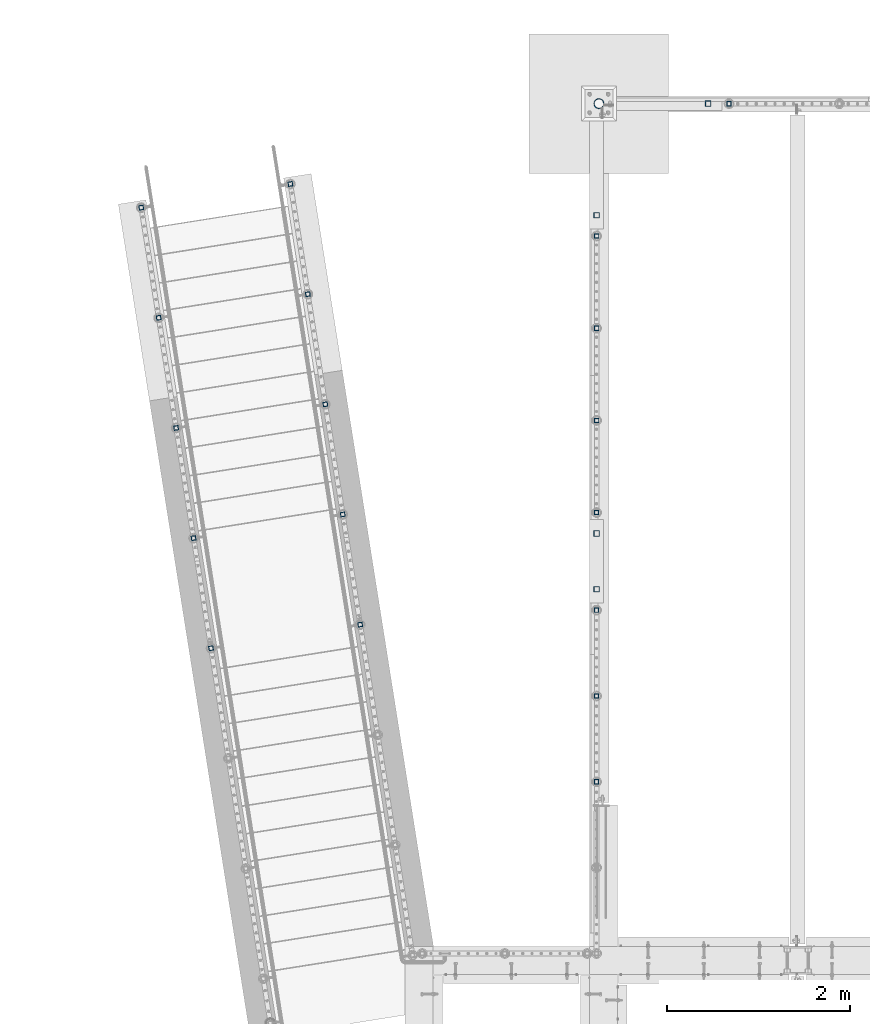
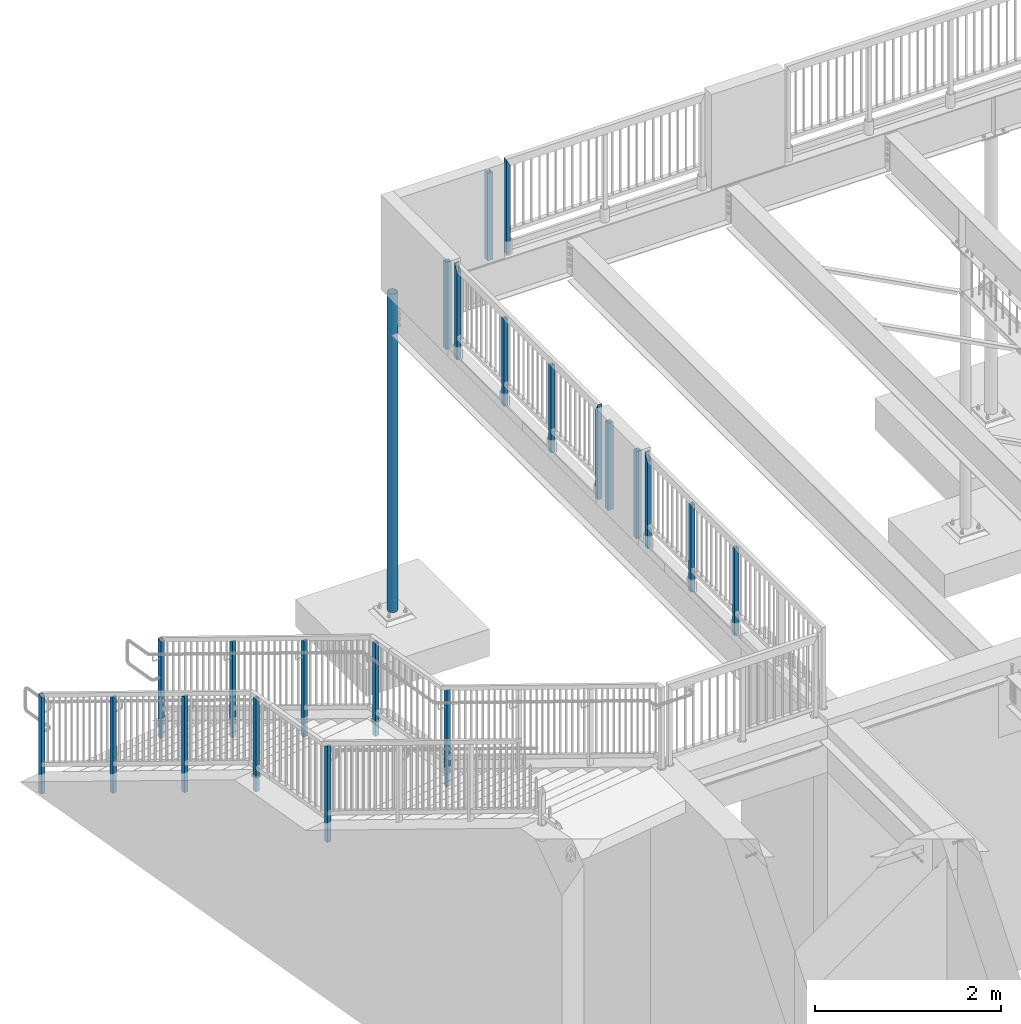
# One storey, part 126 of 975: 23 columns.
"""IFC2X3 building model written with IfcOpenShell, lengths in millimetres."""

from ifc_helpers import new_model, si_unit, frame, origin_with_axes, place, context, subcontext, project, spatial, faceted_brep, material, type_object, element, save


model = new_model("IFC2X3")

# Units and contexts
model_context = context("Model", 3, precision=1e-05, world=origin_with_axes())
body_context = subcontext(model_context, "Body", "Model", "MODEL_VIEW")
ifc_project = project(units=[si_unit("LENGTHUNIT", "METRE", prefix="MILLI"), si_unit("AREAUNIT", "SQUARE_METRE"), si_unit("VOLUMEUNIT", "CUBIC_METRE"), si_unit("MASSUNIT", "GRAM", prefix="KILO"), si_unit("TIMEUNIT", "SECOND"), si_unit("PLANEANGLEUNIT", "RADIAN"), si_unit("SOLIDANGLEUNIT", "STERADIAN"), si_unit("THERMODYNAMICTEMPERATUREUNIT", "DEGREE_CELSIUS"), si_unit("LUMINOUSINTENSITYUNIT", "LUMEN")], contexts=[model_context])

# Site, building, storey
site_placement = place(None, origin_with_axes())
site = spatial("IfcSite", under=ifc_project, at=site_placement, CompositionType="ELEMENT")
building_placement = place(site_placement, origin_with_axes())
building = spatial("IfcBuilding", under=site, at=building_placement, Name="Undefined", CompositionType="ELEMENT")
storey_placement = place(building_placement, origin_with_axes())
storey = spatial("IfcBuildingStorey", under=building, at=storey_placement, Name="Undefined", CompositionType="ELEMENT", Elevation=0.0)

# Columns
ifc_material_1 = material()
column_type_1 = type_object("IfcColumnType", Name="HSS2X2X.188_TUBES", PredefinedType="NOTDEFINED")
column_1_placement = place(storey_placement, frame((3540.12496949157, 29961.8003208815, 3937.00001178547), z_axis=(1.0, 0.0, 0.0), x_axis=(0.0, 0.0, 1.0)))
element("IfcColumn", 1, at=column_1_placement, inside=storey, type_object=column_type_1, material=ifc_material_1, Name="HANDRAIL", ObjectType="HSS2X2X.188_TUBES", context=body_context, shape_type="Brep", body=[
    faceted_brep([(0.0, 20.6374999999753, -20.6375000000298), (0.0, -20.6375000000153, -20.6375000000153), (1235.074979717, -20.6374999999462, -20.6374999999462), (1235.07091767483, 20.6374999999871, -20.6375000000007), (0.0, -20.6374999999825, 20.6375000000335), (1152.52905859553, -20.6375000000121, 20.6375000000007), (0.0, 20.6375000000116, 20.6375000000189), (1152.52497980387, 20.6374999999534, 20.6374999999534), (0.0, 25.3999999999724, -25.4000000000342), (0.0, 25.400000000016, 25.4000000000196), (1143.0, 25.4000000000051, 25.4000000000378), (1244.59497833782, 25.3999999999869, -25.4000000000015), (0.0, -25.399999999976, 25.4000000000378), (1143.00499793254, -25.4000000000121, 25.4000000000015), (0.0, -25.400000000016, -25.4000000000196), (1244.59997970698, -25.399999999936, -25.399999999936)], [[[0, 1, 2, 3]], [[1, 4, 5, 2]], [[4, 6, 7, 5]], [[6, 0, 3, 7]], [[8, 9, 10, 11]], [[9, 12, 13, 10]], [[12, 14, 15, 13]], [[14, 8, 11, 15]], [[13, 15, 11, 10], [5, 7, 3, 2]], [[14, 12, 9, 8], [6, 4, 1, 0]]]),
])
column_2_placement = place(storey_placement, frame((2091.88364504242, 22548.8490121375, 3937.00000847692), z_axis=(0.0, 1.0, 0.0), x_axis=(0.0, 0.0, 1.0)))
element("IfcColumn", 2, at=column_2_placement, inside=storey, type_object=column_type_1, material=ifc_material_1, Name="HANDRAIL", ObjectType="HSS2X2X.188_TUBES", context=body_context, shape_type="Brep", body=[
    faceted_brep([(0.0, 20.6374999999753, -20.6375000000298), (0.0, -20.6375000000153, -20.6375000000153), (1142.99998821453, -20.6374999999462, -20.6374999999534), (1142.99998821453, 20.6374999999462, -20.6374999999516), (0.0, -20.6374999999825, 20.6375000000335), (1142.9999881907, -20.6375000000262, 20.6375000000335), (0.0, 20.6375000000116, 20.6375000000189), (1142.99998829488, 20.6375000000335, 20.637500000048), (0.0, 25.3999999999724, -25.4000000000342), (0.0, 25.400000000016, 25.4000000000196), (1143.0, 25.4000000000051, 25.4000000000378), (1143.0, 25.4000000000433, -25.4000000000087), (0.0, -25.399999999976, 25.4000000000378), (1143.0, -25.4000000000451, 25.4000000000087), (0.0, -25.400000000016, -25.4000000000196), (1143.0, -25.4000000000106, -25.4000000000451)], [[[0, 1, 2, 3]], [[1, 4, 5, 2]], [[4, 6, 7, 5]], [[6, 0, 3, 7]], [[8, 9, 10, 11]], [[9, 12, 13, 10]], [[12, 14, 15, 13]], [[14, 8, 11, 15]], [[13, 15, 11, 10], [5, 7, 3, 2]], [[14, 12, 9, 8], [6, 4, 1, 0]]]),
])
column_3_placement = place(storey_placement, frame((2091.97183575542, 24425.2719553625, 3937.00002018607), z_axis=(0.0, 1.0, 0.0), x_axis=(0.0, 0.0, 1.0)))
element("IfcColumn", 3, at=column_3_placement, inside=storey, type_object=column_type_1, material=ifc_material_1, Name="HANDRAIL", ObjectType="HSS2X2X.188_TUBES", context=body_context, shape_type="Brep", body=[
    faceted_brep([(0.0, 20.6374999999753, -20.6375000000298), (0.0, -20.6375000000153, -20.6375000000153), (1152.52497983932, -20.6374999999462, -20.6374999999525), (1152.53067459427, 20.6374999999998, -20.6375000005137), (0.0, -20.6374999999825, 20.6375000000335), (1235.06928497343, -20.6374999999998, 20.6374999994514), (0.0, 20.6375000000116, 20.6375000000189), (1235.07497982248, 20.6374999999534, 20.6374999999471), (0.0, 25.3999999999724, -25.4000000000342), (0.0, 25.400000000016, 25.4000000000196), (1244.59997982054, 25.399999999936, 25.3999999999351), (1143.00698878129, 25.4000000000001, -25.4000000005108), (0.0, -25.399999999976, 25.4000000000378), (1244.59297078641, -25.4000000000001, 25.3999999994448), (0.0, -25.400000000016, -25.4000000000196), (1143.0, -25.4000000000106, -25.4000000000451)], [[[0, 1, 2, 3]], [[1, 4, 5, 2]], [[4, 6, 7, 5]], [[6, 0, 3, 7]], [[8, 9, 10, 11]], [[9, 12, 13, 10]], [[12, 14, 15, 13]], [[14, 8, 11, 15]], [[13, 15, 11, 10], [5, 7, 3, 2]], [[14, 12, 9, 8], [6, 4, 1, 0]]]),
])
for number, where, z_axis, x_axis, name in (
    (4, (2091.98883508309, 23487.0582877675, 3937.00001429355), (0.0, 1.0, 0.0), (0.0, 0.0, 1.0), "HANDRAIL"),
    (5, (2092.32592453032, 26499.6095286945, 3937.0), (0.0, 1.0, 0.0), (0.0, 0.0, 1.0), "HANDRAIL"),
):
    element("IfcColumn", number, at=place(storey_placement, frame(where, z_axis=z_axis, x_axis=x_axis)), inside=storey, type_object=column_type_1, material=ifc_material_1, Name=name, ObjectType="HSS2X2X.188_TUBES", context=body_context, shape_type="Brep", body=[
        faceted_brep([(0.0, 20.6374999999753, -20.6375000000298), (0.0, -20.6375000000153, -20.6375000000153), (1142.99998821453, -20.6374999999462, -20.6374999999534), (1142.99998821453, 20.6374999999462, -20.6374999999516), (0.0, -20.6374999999825, 20.6375000000335), (1142.9999881907, -20.6375000000262, 20.6375000000335), (0.0, 20.6375000000116, 20.6375000000189), (1142.99998829488, 20.6375000000335, 20.637500000048), (0.0, 25.3999999999724, -25.4000000000342), (0.0, 25.400000000016, 25.4000000000196), (1143.0, 25.4000000000051, 25.4000000000378), (1143.0, 25.4000000000433, -25.4000000000087), (0.0, -25.399999999976, 25.4000000000378), (1143.0, -25.4000000000451, 25.4000000000087), (0.0, -25.400000000016, -25.4000000000196), (1143.0, -25.4000000000106, -25.4000000000451)], [[[0, 1, 2, 3]], [[1, 4, 5, 2]], [[4, 6, 7, 5]], [[6, 0, 3, 7]], [[8, 9, 10, 11]], [[9, 12, 13, 10]], [[12, 14, 15, 13]], [[14, 8, 11, 15]], [[13, 15, 11, 10], [5, 7, 3, 2]], [[14, 12, 9, 8], [6, 4, 1, 0]]]),
    ])
column_4_placement = place(storey_placement, frame((2092.44052223528, 28514.6750001206, 3937.00002018607), z_axis=(0.0, 1.0, 0.0), x_axis=(0.0, 0.0, 1.0)))
element("IfcColumn", 6, at=column_4_placement, inside=storey, type_object=column_type_1, material=ifc_material_1, Name="HANDRAIL", ObjectType="HSS2X2X.188_TUBES", context=body_context, shape_type="Brep", body=[
    faceted_brep([(0.0, 20.6374999999753, -20.6375000000298), (0.0, -20.6375000000153, -20.6375000000153), (1152.52497983932, -20.6374999999462, -20.6374999999525), (1152.5298588527, 20.6374999999998, -20.6375000005173), (0.0, -20.6374999999825, 20.6375000000335), (1235.07010081906, -20.6374999999998, 20.6374999994514), (0.0, 20.6375000000116, 20.6375000000189), (1235.07497982248, 20.6374999999534, 20.6374999999471), (0.0, 25.3999999999724, -25.4000000000342), (0.0, 25.400000000016, 25.4000000000196), (1244.59997982054, 25.399999999936, 25.3999999999351), (1143.00598477966, 25.4000000000001, -25.4000000005108), (0.0, -25.399999999976, 25.4000000000378), (1244.59397489211, -25.4000000000001, 25.3999999994448), (0.0, -25.400000000016, -25.4000000000196), (1143.0, -25.4000000000106, -25.4000000000451)], [[[0, 1, 2, 3]], [[1, 4, 5, 2]], [[4, 6, 7, 5]], [[6, 0, 3, 7]], [[8, 9, 10, 11]], [[9, 12, 13, 10]], [[12, 14, 15, 13]], [[14, 8, 11, 15]], [[13, 15, 11, 10], [5, 7, 3, 2]], [[14, 12, 9, 8], [6, 4, 1, 0]]]),
])
column_5_placement = place(storey_placement, frame((2092.44294281713, 27507.1418341241, 3937.0), z_axis=(0.0, 1.0, 0.0), x_axis=(0.0, 0.0, 1.0)))
element("IfcColumn", 7, at=column_5_placement, inside=storey, type_object=column_type_1, material=ifc_material_1, Name="HANDRAIL", ObjectType="HSS2X2X.188_TUBES", context=body_context, shape_type="Brep", body=[
    faceted_brep([(0.0, 20.6374999999753, -20.6375000000298), (0.0, -20.6375000000153, -20.6375000000153), (1142.99998821453, -20.6374999999462, -20.6374999999534), (1142.99998821453, 20.6374999999462, -20.6374999999516), (0.0, -20.6374999999825, 20.6375000000335), (1142.9999881907, -20.6375000000262, 20.6375000000335), (0.0, 20.6375000000116, 20.6375000000189), (1142.99998829488, 20.6375000000335, 20.637500000048), (0.0, 25.3999999999724, -25.4000000000342), (0.0, 25.400000000016, 25.4000000000196), (1143.0, 25.4000000000051, 25.4000000000378), (1143.0, 25.4000000000433, -25.4000000000087), (0.0, -25.399999999976, 25.4000000000378), (1143.0, -25.4000000000451, 25.4000000000087), (0.0, -25.400000000016, -25.4000000000196), (1143.0, -25.4000000000106, -25.4000000000451)], [[[0, 1, 2, 3]], [[1, 4, 5, 2]], [[4, 6, 7, 5]], [[6, 0, 3, 7]], [[8, 9, 10, 11]], [[9, 12, 13, 10]], [[12, 14, 15, 13]], [[14, 8, 11, 15]], [[13, 15, 11, 10], [5, 7, 3, 2]], [[14, 12, 9, 8], [6, 4, 1, 0]]]),
])
column_6_placement = place(storey_placement, frame((2092.2586399658, 25492.078072198, 3937.0), z_axis=(0.0, 1.0, 0.0), x_axis=(0.0, 0.0, 1.0)))
element("IfcColumn", 8, at=column_6_placement, inside=storey, type_object=column_type_1, material=ifc_material_1, Name="HANDRAIL", ObjectType="HSS2X2X.188_TUBES", context=body_context, shape_type="Brep", body=[
    faceted_brep([(0.0, 20.6374999999753, -20.6375000000298), (0.0, -20.6375000000153, -20.6375000000153), (1235.074979717, -20.6374999999462, -20.6374999999462), (1235.07010917575, 20.6374999999871, -20.6375000000007), (0.0, -20.6374999999825, 20.6375000000335), (1152.5298672094, -20.6375000000121, 20.6375000000007), (0.0, 20.6375000000116, 20.6375000000189), (1152.52497980387, 20.6374999999534, 20.6374999999534), (0.0, 25.3999999999724, -25.4000000000342), (0.0, 25.400000000016, 25.4000000000196), (1143.0, 25.4000000000051, 25.4000000000378), (1244.5939832488, 25.3999999999869, -25.4000000000015), (0.0, -25.399999999976, 25.4000000000378), (1143.00599313636, -25.4000000000124, 25.4000000000015), (0.0, -25.400000000016, -25.4000000000196), (1244.59997970698, -25.399999999936, -25.399999999936)], [[[0, 1, 2, 3]], [[1, 4, 5, 2]], [[4, 6, 7, 5]], [[6, 0, 3, 7]], [[8, 9, 10, 11]], [[9, 12, 13, 10]], [[12, 14, 15, 13]], [[14, 8, 11, 15]], [[13, 15, 11, 10], [5, 7, 3, 2]], [[14, 12, 9, 8], [6, 4, 1, 0]]]),
])
column_7_placement = place(storey_placement, frame((-2123.13173536814, 24008.8661433573, 1816.09989624178), z_axis=(-0.987688340611262, -0.156434464938429, 0.0), x_axis=(-9.82000000013435e-07, 6.19899999951672e-06, 0.999999999980304)))
element("IfcColumn", 9, at=column_7_placement, inside=storey, type_object=column_type_1, material=ifc_material_1, Name="HANDRAIL", ObjectType="HSS2X2X.188_TUBES", context=body_context, shape_type="Brep", body=[
    faceted_brep([(0.0, 20.6374999999753, -20.6375000000298), (0.0, -20.6375000000153, -20.6375000000153), (1265.43474246505, -20.6375000006701, -20.6374999998047), (1242.64784025711, 20.6374999993641, -20.6374999998047), (0.0, -20.6374999999825, 20.6375000000335), (1265.43474243091, -20.637500000641, 20.6375000001958), (0.0, 20.6375000000116, 20.6375000000189), (1242.64784022297, 20.6374999993932, 20.6375000001954), (0.0, 25.3999999999724, -25.4000000000342), (0.0, 25.400000000016, 25.4000000000196), (1240.01858227196, 25.3999999994012, 25.4000000001959), (1240.01858231398, 25.3999999993648, -25.3999999998052), (0.0, -25.399999999976, 25.4000000000378), (1268.06400037404, -25.4000000006417, 25.4000000001963), (0.0, -25.400000000016, -25.4000000000196), (1268.06400041606, -25.4000000006745, -25.3999999998048)], [[[0, 1, 2, 3]], [[1, 4, 5, 2]], [[4, 6, 7, 5]], [[6, 0, 3, 7]], [[8, 9, 10, 11]], [[9, 12, 13, 10]], [[12, 14, 15, 13]], [[14, 8, 11, 15]], [[13, 15, 11, 10], [5, 7, 3, 2]], [[14, 12, 9, 8], [6, 4, 1, 0]]]),
])
column_8_placement = place(storey_placement, frame((-2313.85792260021, 25213.0635193831, 1816.09996027484), z_axis=(-0.987688340611262, -0.156434464938429, 0.0), x_axis=(0.0, 0.0, 1.0)))
element("IfcColumn", 10, at=column_8_placement, inside=storey, type_object=column_type_1, material=ifc_material_1, Name="HANDRAIL", ObjectType="HSS2X2X.188_TUBES", context=body_context, shape_type="Brep", body=[
    faceted_brep([(0.0, 20.6374999999753, -20.6375000000298), (0.0, -20.6375000000153, -20.6375000000153), (1219.19848467923, -20.6374999999935, -20.6375), (1219.19914673023, 20.6374999999716, -20.6375000000028), (0.0, -20.6374999999825, 20.6375000000335), (1219.19848467923, -20.6374999999643, 20.637500000001), (0.0, 20.6375000000116, 20.6375000000189), (1219.19914673023, 20.6375000000007, 20.6374999999982), (0.0, 25.3999999999724, -25.4000000000342), (0.0, 25.400000000016, 25.4000000000196), (1219.19922312073, 25.4000000000015, 25.3999999999976), (1219.19922312073, 25.3999999999651, -25.400000000003), (0.0, -25.399999999976, 25.4000000000378), (1219.19840828873, -25.3999999999578, 25.4000000000012), (0.0, -25.400000000016, -25.4000000000196), (1219.19840828873, -25.3999999999942, -25.399999999999)], [[[0, 1, 2, 3]], [[1, 4, 5, 2]], [[4, 6, 7, 5]], [[6, 0, 3, 7]], [[8, 9, 10, 11]], [[9, 12, 13, 10]], [[12, 14, 15, 13]], [[14, 8, 11, 15]], [[13, 15, 11, 10], [5, 7, 3, 2]], [[14, 12, 9, 8], [6, 4, 1, 0]]]),
])
column_9_placement = place(storey_placement, frame((-2504.5829053629, 26417.2533289457, 1143.00014462518), z_axis=(-0.987688340611262, -0.156434464938429, 0.0), x_axis=(0.0, 0.0, 1.0)))
element("IfcColumn", 11, at=column_9_placement, inside=storey, type_object=column_type_1, material=ifc_material_1, Name="HANDRAIL", ObjectType="HSS2X2X.188_TUBES", context=body_context, shape_type="Brep", body=[
    faceted_brep([(0.0, 20.6374999999753, -20.6375000000298), (0.0, -20.6375000000153, -20.6375000000153), (1265.43455043025, -20.6374999999898, -20.6375000000003), (1242.64731021461, 20.6374999999716, -20.6375000000025), (0.0, -20.6374999999825, 20.6375000000335), (1265.43455043025, -20.6374999999607, 20.6375000000007), (0.0, 20.6375000000116, 20.6375000000189), (1242.64731021461, 20.6375000000007, 20.6374999999985), (0.0, 25.3999999999724, -25.4000000000342), (0.0, 25.400000000016, 25.4000000000196), (1240.01801326665, 25.4000000000051, 25.3999999999974), (1240.01801326666, 25.3999999999651, -25.4000000000028), (0.0, -25.399999999976, 25.4000000000378), (1268.06384737821, -25.3999999999542, 25.400000000001), (0.0, -25.400000000016, -25.4000000000196), (1268.06384737821, -25.3999999999942, -25.3999999999992)], [[[0, 1, 2, 3]], [[1, 4, 5, 2]], [[4, 6, 7, 5]], [[6, 0, 3, 7]], [[8, 9, 10, 11]], [[9, 12, 13, 10]], [[12, 14, 15, 13]], [[14, 8, 11, 15]], [[13, 15, 11, 10], [5, 7, 3, 2]], [[14, 12, 9, 8], [6, 4, 1, 0]]]),
])
column_10_placement = place(storey_placement, frame((-2695.30784146736, 27621.4428438849, 469.900046968934), z_axis=(-0.987688340611262, -0.156434464938429, 0.0), x_axis=(0.0, 0.0, 1.0)))
element("IfcColumn", 12, at=column_10_placement, inside=storey, type_object=column_type_1, material=ifc_material_1, Name="HANDRAIL", ObjectType="HSS2X2X.188_TUBES", context=body_context, shape_type="Brep", body=[
    faceted_brep([(0.0, 20.6374999999753, -20.6375000000298), (0.0, -20.6375000000153, -20.6375000000153), (1265.43468620725, -20.6374999999971, -20.6374999999989), (1242.64744599161, 20.637499999968, -20.6375000000012), (0.0, -20.6374999999825, 20.6375000000335), (1265.43468620725, -20.637499999968, 20.6375000000016), (0.0, 20.6375000000116, 20.6375000000189), (1242.6474459916, 20.6374999999971, 20.6374999999994), (0.0, 25.3999999999724, -25.4000000000342), (0.0, 25.400000000016, 25.4000000000196), (1240.01814904365, 25.3999999999978, 25.3999999999983), (1240.01814904365, 25.3999999999614, -25.4000000000015), (0.0, -25.399999999976, 25.4000000000378), (1268.06400037404, -25.4000000006417, 25.4000000001963), (0.0, -25.400000000016, -25.4000000000196), (1268.06400041606, -25.4000000006745, -25.3999999998048)], [[[0, 1, 2, 3]], [[1, 4, 5, 2]], [[4, 6, 7, 5]], [[6, 0, 3, 7]], [[8, 9, 10, 11]], [[9, 12, 13, 10]], [[12, 14, 15, 13]], [[14, 8, 11, 15]], [[13, 15, 11, 10], [5, 7, 3, 2]], [[14, 12, 9, 8], [6, 4, 1, 0]]]),
])
column_11_placement = place(storey_placement, frame((-2886.0328095457, 28825.6325606995, -203.199996748907), z_axis=(-0.987688340611262, -0.156434464938429, 0.0), x_axis=(0.0, 0.0, 1.0)))
element("IfcColumn", 13, at=column_11_placement, inside=storey, type_object=column_type_1, material=ifc_material_1, Name="HANDRAIL", ObjectType="HSS2X2X.188_TUBES", context=body_context, shape_type="Brep", body=[
    faceted_brep([(0.0, 20.6374999999753, -20.6375000000298), (0.0, -20.6375000000153, -20.6375000000153), (1270.87474648145, -20.6374999988802, -20.6375000001763), (1295.23497647836, 20.6375000011103, -20.6375000001822), (0.0, -20.6374999999825, 20.6375000000335), (1270.87474646853, -20.6374999988511, 20.6374999998247), (0.0, 20.6375000000116, 20.6375000000189), (1295.23497646545, 20.6375000011358, 20.6374999998188), (0.0, 25.3999999999724, -25.4000000000342), (0.0, 25.400000000016, 25.4000000000196), (1298.04577223283, 25.4000000011365, 25.3999999998175), (1298.04577224873, 25.4000000011038, -25.4000000001836), (0.0, -25.399999999976, 25.4000000000378), (1268.06392646791, -25.400000001744, 25.4000000002593), (0.0, -25.400000000016, -25.4000000000196), (1268.06392650826, -25.4000000017732, -25.3999999997307)], [[[0, 1, 2, 3]], [[1, 4, 5, 2]], [[4, 6, 7, 5]], [[6, 0, 3, 7]], [[8, 9, 10, 11]], [[9, 12, 13, 10]], [[12, 14, 15, 13]], [[14, 8, 11, 15]], [[13, 15, 11, 10], [5, 7, 3, 2]], [[14, 12, 9, 8], [6, 4, 1, 0]]]),
])
column_12_placement = place(storey_placement, frame((-492.265792255981, 24267.1780900281, 1816.09989608206), z_axis=(0.987688352468583, 0.156434390074216, -6.09999983468464e-08), x_axis=(0.0, 0.0, 1.0)))
element("IfcColumn", 14, at=column_12_placement, inside=storey, type_object=column_type_1, material=ifc_material_1, Name="HANDRAIL", ObjectType="HSS2X2X.188_TUBES", context=body_context, shape_type="Brep", body=[
    faceted_brep([(0.0, 20.6374999999753, -20.6375000000298), (0.0, -20.6375000000153, -20.6375000000153), (1242.64756997557, -20.6374999999971, -20.6375000000003), (1265.43481035084, 20.637499999968, -20.6374999999953), (0.0, -20.6374999999825, 20.6375000000335), (1242.64756991491, -20.637499999968, 20.6374999999953), (0.0, 20.6375000000116, 20.6375000000189), (1265.43481029018, 20.6374999999935, 20.6375000000003), (0.0, 25.3999999999724, -25.4000000000342), (0.0, 25.400000000016, 25.4000000000196), (1268.06410724956, 25.3999999999978, 25.4000000000001), (1268.06410732422, 25.3999999999578, -25.3999999999937), (0.0, -25.399999999976, 25.4000000000378), (1240.01827294153, -25.3999999999614, 25.3999999999937), (0.0, -25.400000000016, -25.4000000000196), (1240.01827301619, -25.4000000000015, -25.4000000000005)], [[[0, 1, 2, 3]], [[1, 4, 5, 2]], [[4, 6, 7, 5]], [[6, 0, 3, 7]], [[8, 9, 10, 11]], [[9, 12, 13, 10]], [[12, 14, 15, 13]], [[14, 8, 11, 15]], [[13, 15, 11, 10], [5, 7, 3, 2]], [[14, 12, 9, 8], [6, 4, 1, 0]]]),
])
column_13_placement = place(storey_placement, frame((-682.990602503871, 25471.3675271442, 1816.09996027484), z_axis=(0.987688352468583, 0.156434390074216, -6.09999983468464e-08), x_axis=(0.0, 0.0, 1.0)))
element("IfcColumn", 15, at=column_13_placement, inside=storey, type_object=column_type_1, material=ifc_material_1, Name="HANDRAIL", ObjectType="HSS2X2X.188_TUBES", context=body_context, shape_type="Brep", body=[
    faceted_brep([(0.0, 20.6374999999753, -20.6375000000298), (0.0, -20.6375000000153, -20.6375000000153), (1219.19914664517, -20.6374999999971, -20.6375000000012), (1219.19848459417, 20.637499999968, -20.6374999999939), (0.0, -20.6374999999825, 20.6375000000335), (1219.19914664517, -20.637499999968, 20.6374999999948), (0.0, 20.6375000000116, 20.6375000000189), (1219.19848459417, 20.6374999999971, 20.6375000000016), (0.0, 25.3999999999724, -25.4000000000342), (0.0, 25.400000000016, 25.4000000000196), (1219.19840820367, 25.3999999999978, 25.4000000000019), (1219.19840820367, 25.3999999999651, -25.3999999999933), (0.0, -25.399999999976, 25.4000000000378), (1219.19922303567, -25.3999999999614, 25.3999999999937), (0.0, -25.400000000016, -25.4000000000196), (1219.19922303567, -25.3999999999978, -25.400000000001)], [[[0, 1, 2, 3]], [[1, 4, 5, 2]], [[4, 6, 7, 5]], [[6, 0, 3, 7]], [[8, 9, 10, 11]], [[9, 12, 13, 10]], [[12, 14, 15, 13]], [[14, 8, 11, 15]], [[13, 15, 11, 10], [5, 7, 3, 2]], [[14, 12, 9, 8], [6, 4, 1, 0]]]),
])
column_14_placement = place(storey_placement, frame((-873.715479431632, 26675.5573464666, 1143.00014462518), z_axis=(0.987688352468583, 0.156434390074216, -6.09999983468464e-08), x_axis=(0.0, 0.0, 1.0)))
element("IfcColumn", 16, at=column_14_placement, inside=storey, type_object=column_type_1, material=ifc_material_1, Name="HANDRAIL", ObjectType="HSS2X2X.188_TUBES", context=body_context, shape_type="Brep", body=[
    faceted_brep([(0.0, 20.6374999999753, -20.6375000000298), (0.0, -20.6375000000153, -20.6375000000153), (1242.64731064646, -20.6374999982581, -20.6375000002636), (1265.43455058778, 20.6375000017397, -20.6375000002618), (0.0, -20.6374999999825, 20.6375000000335), (1242.64731063797, -20.6374999982327, 20.6374999997324), (0.0, 20.6375000000116, 20.6375000000189), (1265.43455057928, 20.6375000017688, 20.6374999997342), (0.0, 25.3999999999724, -25.4000000000342), (0.0, 25.400000000016, 25.4000000000196), (1268.06384749461, 25.4000000017695, 25.3999999997336), (1268.06384750506, 25.4000000017404, -25.4000000002616), (0.0, -25.399999999976, 25.4000000000378), (1240.01801372068, -25.3999999982261, 25.3999999997313), (0.0, -25.400000000016, -25.4000000000196), (1240.01801373114, -25.3999999982625, -25.4000000002629)], [[[0, 1, 2, 3]], [[1, 4, 5, 2]], [[4, 6, 7, 5]], [[6, 0, 3, 7]], [[8, 9, 10, 11]], [[9, 12, 13, 10]], [[12, 14, 15, 13]], [[14, 8, 11, 15]], [[13, 15, 11, 10], [5, 7, 3, 2]], [[14, 12, 9, 8], [6, 4, 1, 0]]]),
])
column_15_placement = place(storey_placement, frame((-1064.44031078204, 27879.7468779936, 469.900046968934), z_axis=(0.987688352468583, 0.156434390074216, -6.09999983468464e-08), x_axis=(0.0, 0.0, 1.0)))
element("IfcColumn", 17, at=column_15_placement, inside=storey, type_object=column_type_1, material=ifc_material_1, Name="HANDRAIL", ObjectType="HSS2X2X.188_TUBES", context=body_context, shape_type="Brep", body=[
    faceted_brep([(0.0, 20.6374999999753, -20.6375000000298), (0.0, -20.6375000000153, -20.6375000000153), (1242.64744642528, -20.6374999982618, -20.6375000002595), (1265.43468636659, 20.637500001736, -20.6375000002586), (0.0, -20.6374999999825, 20.6375000000335), (1242.64744641678, -20.6374999982363, 20.6374999997315), (0.0, 20.6375000000116, 20.6375000000189), (1265.43468635809, 20.6375000017651, 20.637499999732), (0.0, 25.3999999999724, -25.4000000000342), (0.0, 25.400000000016, 25.4000000000196), (1268.06398327342, 25.4000000017695, 25.3999999997318), (1268.06398328388, 25.4000000017331, -25.4000000002579), (0.0, -25.399999999976, 25.4000000000378), (1240.0181494995, -25.3999999982298, 25.3999999997295), (0.0, -25.400000000016, -25.4000000000196), (1240.01814950995, -25.3999999982661, -25.4000000002593)], [[[0, 1, 2, 3]], [[1, 4, 5, 2]], [[4, 6, 7, 5]], [[6, 0, 3, 7]], [[8, 9, 10, 11]], [[9, 12, 13, 10]], [[12, 14, 15, 13]], [[14, 8, 11, 15]], [[13, 15, 11, 10], [5, 7, 3, 2]], [[14, 12, 9, 8], [6, 4, 1, 0]]]),
])
column_16_placement = place(storey_placement, frame((-1255.16517517354, 29083.9366181338, -203.199996545447), z_axis=(0.987688352468583, 0.156434390074216, -6.09999983468464e-08), x_axis=(0.0, 0.0, 1.0)))
element("IfcColumn", 18, at=column_16_placement, inside=storey, type_object=column_type_1, material=ifc_material_1, Name="HANDRAIL", ObjectType="HSS2X2X.188_TUBES", context=body_context, shape_type="Brep", body=[
    faceted_brep([(0.0, 20.6374999999753, -20.6375000000298), (0.0, -20.6375000000153, -20.6375000000153), (1295.23497631638, -20.6375000011358, -20.6374999998184), (1270.87474631947, 20.6374999988548, -20.6374999998152), (0.0, -20.6374999999825, 20.6375000000335), (1295.2349763293, -20.6375000011103, 20.6375000001731), (0.0, 20.6375000000116, 20.6375000000189), (1270.87474633239, 20.6374999988802, 20.6375000001754), (0.0, 25.3999999999724, -25.4000000000342), (0.0, 25.400000000016, 25.4000000000196), (1268.06392601805, 25.3999999999942, 25.4000000000019), (1268.06392606885, 25.3999999999578, -25.3999999999928), (0.0, -25.399999999976, 25.4000000000378), (1298.04577209967, -25.4000000011038, 25.4000000001724), (0.0, -25.400000000016, -25.4000000000196), (1298.04577208376, -25.4000000011365, -25.3999999998173)], [[[0, 1, 2, 3]], [[1, 4, 5, 2]], [[4, 6, 7, 5]], [[6, 0, 3, 7]], [[8, 9, 10, 11]], [[9, 12, 13, 10]], [[12, 14, 15, 13]], [[14, 8, 11, 15]], [[13, 15, 11, 10], [5, 7, 3, 2]], [[14, 12, 9, 8], [6, 4, 1, 0]]]),
])
column_type_2 = type_object("IfcColumnType", Name="HSS2-1/2X2-1/2X1/4", PredefinedType="NOTDEFINED")
for number, where, z_axis, x_axis in (
    (19, (3311.525, 29962.475, 3937.0), (0.0, 1.0, 0.0), (0.0, 0.0, 1.0)),
    (20, (2092.325, 28743.275, 3937.0), (0.0, 1.0, 0.0), (0.0, 0.0, 1.0)),
    (21, (2092.38540517953, 25263.4748204749, 3937.0), (0.0, 1.0, 0.0), (0.0, 0.0, 1.0)),
    (22, (2092.38540517953, 24653.8748204749, 3937.0), (0.0, 1.0, 0.0), (0.0, 0.0, 1.0)),
):
    element("IfcColumn", number, at=place(storey_placement, frame(where, z_axis=z_axis, x_axis=x_axis)), inside=storey, type_object=column_type_2, material=ifc_material_1, ObjectType="HSS2-1/2X2-1/2X1/4", context=body_context, shape_type="Brep", body=[
        faceted_brep([(0.0, 25.3999999999724, -25.4000000000342), (0.0, -25.400000000016, -25.4000000000196), (1143.0, -25.4000000000106, -25.4000000000451), (1143.0, 25.4000000000433, -25.4000000000087), (0.0, -25.399999999976, 25.4000000000378), (1143.0, -25.4000000000451, 25.4000000000087), (0.0, 25.400000000016, 25.4000000000196), (1143.0, 25.4000000000051, 25.4000000000378), (-5.45696821063757e-11, 31.7499999999909, -31.75000000002), (0.0, 31.7500000000127, 31.7500000000582), (1143.0, 31.7500000000127, 31.7500000000582), (1143.0, 31.7500000000546, -31.7500000000146), (0.0, -31.7500000000564, 31.7500000000073), (1143.0, -31.7500000000564, 31.7500000000073), (0.0, -31.7500000000146, -31.7500000000582), (1143.0, -31.7500000000146, -31.7500000000582)], [[[0, 1, 2, 3]], [[1, 4, 5, 2]], [[4, 6, 7, 5]], [[6, 0, 3, 7]], [[8, 9, 10, 11]], [[9, 12, 13, 10]], [[12, 14, 15, 13]], [[14, 8, 11, 15]], [[13, 15, 11, 10], [5, 7, 3, 2]], [[14, 12, 9, 8], [6, 4, 1, 0]]]),
    ])
ifc_material_2 = material(Name="STEEL/A53")
column_type_3 = type_object("IfcColumnType", Name="PIPE4XS", PredefinedType="NOTDEFINED")
column_17_placement = place(storey_placement, frame((2117.725, 29962.475, -266.7), z_axis=(0.0, 1.0, 0.0), x_axis=(0.0, 0.0, 1.0)))
element("IfcColumn", 23, at=column_17_placement, inside=storey, type_object=column_type_3, material=ifc_material_2, Name="COLUMN", ObjectType="PIPE4XS", context=body_context, shape_type="Brep", body=[
    faceted_brep([(19.050000000004, -48.5902000000006, 0.0), (19.050000000004, -46.2120263380839, 15.0151975600784), (4194.175, -46.2120263380839, 15.0151975600784), (4194.175, -48.5902000000006, 0.0), (19.050000000004, -39.3102975600777, 28.560602965943), (4194.175, -39.3102975600777, 28.560602965943), (19.050000000004, -28.560602965943, 39.3102975600777), (4194.175, -28.560602965943, 39.3102975600777), (19.050000000004, -15.0151975600784, 46.2120263380857), (4194.175, -15.0151975600784, 46.2120263380857), (19.050000000004, 0.0, 48.5901999999987), (4194.175, 0.0, 48.5901999999987), (19.050000000004, 15.0151975600784, 46.2120263380857), (4194.175, 15.0151975600784, 46.2120263380857), (19.050000000004, 28.560602965943, 39.3102975600777), (4194.175, 28.560602965943, 39.3102975600777), (19.050000000004, 39.3102975600777, 28.560602965943), (4194.175, 39.3102975600777, 28.560602965943), (19.050000000004, 46.2120263380857, 15.0151975600784), (4194.175, 46.2120263380857, 15.0151975600784), (19.050000000004, 48.5901999999987, 0.0), (4194.175, 48.5901999999987, 0.0), (19.050000000004, 46.2120263380857, -15.0151975600784), (4194.175, 46.2120263380857, -15.0151975600784), (19.050000000004, 39.3102975600777, -28.560602965943), (4194.175, 39.3102975600777, -28.560602965943), (19.050000000004, 28.560602965943, -39.3102975600777), (4194.175, 28.560602965943, -39.3102975600777), (19.050000000004, 15.0151975600784, -46.2120263380857), (4194.175, 15.0151975600784, -46.2120263380857), (19.050000000004, 0.0, -48.5901999999987), (4194.175, 0.0, -48.5901999999987), (19.050000000004, -15.0151975600784, -46.2120263380857), (4194.175, -15.0151975600784, -46.2120263380857), (19.050000000004, -28.560602965943, -39.3102975600777), (4194.175, -28.560602965943, -39.3102975600777), (19.050000000004, -39.3102975600777, -28.560602965943), (4194.175, -39.3102975600777, -28.560602965943), (19.050000000004, -46.2120263380839, -15.0151975600784), (4194.175, -46.2120263380839, -15.0151975600784), (19.0500000000025, -57.1499999999996, 0.0), (19.0500000000025, -54.3528799062678, -17.6603212285299), (4194.175, -54.3528799062678, -17.6603212285299), (4194.175, -57.1499999999996, 0.0), (19.0500000000025, -46.2353212285279, -33.5919271685161), (4194.175, -46.2353212285288, -33.5919271685161), (19.0500000000025, -33.5919271685152, -46.235321228527), (4194.175, -33.5919271685161, -46.235321228527), (19.0500000000025, -17.6603212285281, -54.3528799062697), (4194.175, -17.6603212285299, -54.3528799062697), (19.0500000000025, 0.0, -57.1500000000015), (4194.175, 0.0, -57.1500000000015), (19.0500000000025, 17.6603212285281, -54.3528799062697), (4194.175, 17.6603212285299, -54.3528799062697), (19.0500000000025, 33.5919271685152, -46.235321228527), (4194.175, 33.5919271685161, -46.235321228527), (19.0500000000025, 46.2353212285279, -33.5919271685161), (4194.175, 46.235321228527, -33.5919271685161), (19.0500000000025, 54.3528799062678, -17.6603212285299), (4194.175, 54.3528799062697, -17.6603212285299), (19.0500000000025, 57.1499999999996, 0.0), (4194.175, 57.1500000000015, 0.0), (19.0500000000025, 54.3528799062678, 17.6603212285299), (4194.175, 54.3528799062697, 17.6603212285299), (19.0500000000025, 46.2353212285279, 33.5919271685161), (4194.175, 46.235321228527, 33.5919271685161), (19.0500000000025, 33.5919271685152, 46.235321228527), (4194.175, 33.5919271685161, 46.235321228527), (19.0500000000025, 17.6603212285281, 54.3528799062697), (4194.175, 17.6603212285299, 54.3528799062697), (19.0500000000025, 0.0, 57.1500000000015), (4194.175, 0.0, 57.1500000000015), (19.0500000000025, -17.6603212285281, 54.3528799062697), (4194.175, -17.6603212285299, 54.3528799062697), (19.0500000000025, -33.5919271685152, 46.235321228527), (4194.175, -33.5919271685161, 46.235321228527), (19.0500000000025, -46.2353212285279, 33.5919271685161), (4194.175, -46.2353212285288, 33.5919271685161), (19.0500000000025, -54.3528799062678, 17.6603212285299), (4194.175, -54.3528799062678, 17.6603212285299)], [[[0, 1, 2, 3]], [[1, 4, 5, 2]], [[4, 6, 7, 5]], [[6, 8, 9, 7]], [[8, 10, 11, 9]], [[10, 12, 13, 11]], [[12, 14, 15, 13]], [[14, 16, 17, 15]], [[16, 18, 19, 17]], [[18, 20, 21, 19]], [[20, 22, 23, 21]], [[22, 24, 25, 23]], [[24, 26, 27, 25]], [[26, 28, 29, 27]], [[28, 30, 31, 29]], [[30, 32, 33, 31]], [[32, 34, 35, 33]], [[34, 36, 37, 35]], [[36, 38, 39, 37]], [[38, 0, 3, 39]], [[40, 41, 42, 43]], [[41, 44, 45, 42]], [[44, 46, 47, 45]], [[46, 48, 49, 47]], [[48, 50, 51, 49]], [[50, 52, 53, 51]], [[52, 54, 55, 53]], [[54, 56, 57, 55]], [[56, 58, 59, 57]], [[58, 60, 61, 59]], [[60, 62, 63, 61]], [[62, 64, 65, 63]], [[64, 66, 67, 65]], [[66, 68, 69, 67]], [[68, 70, 71, 69]], [[70, 72, 73, 71]], [[72, 74, 75, 73]], [[74, 76, 77, 75]], [[76, 78, 79, 77]], [[78, 40, 43, 79]], [[45, 47, 49, 51, 53, 55, 57, 59, 61, 63, 65, 67, 69, 71, 73, 75, 77, 79, 43, 42], [5, 7, 9, 11, 13, 15, 17, 19, 21, 23, 25, 27, 29, 31, 33, 35, 37, 39, 3, 2]], [[78, 76, 74, 72, 70, 68, 66, 64, 62, 60, 58, 56, 54, 52, 50, 48, 46, 44, 41, 40], [38, 36, 34, 32, 30, 28, 26, 24, 22, 20, 18, 16, 14, 12, 10, 8, 6, 4, 1, 0]]]),
])

save(model, "model.ifc")
